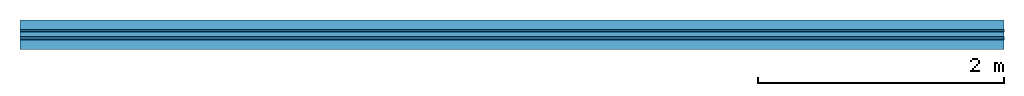
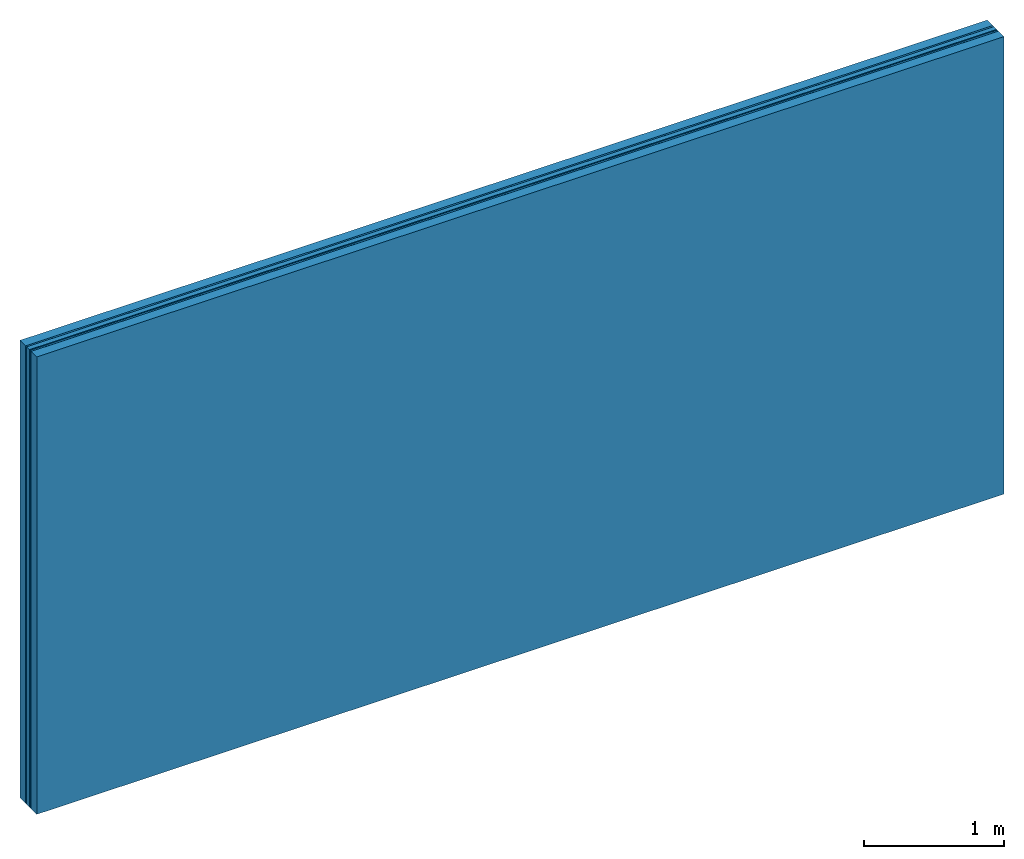
# One storey: 4 plates, 2 members, 1 element without a shape of its own.
"""IFC4 building model written with IfcOpenShell, lengths in metres."""

import ifcopenshell
import ifcopenshell.guid

model = None  # the IFC model being written
_history = None  # IfcOwnerHistory: only IFC2X3 demands one
_inside = {}  # id of a spatial element -> (the spatial element, [elements in it])
_under = {}  # id of a project, library or spatial element -> (it, [spatial elements below it])
_declared = {}  # id of a project -> (the project, [libraries it declares])
_typed = {}  # id of a type object -> (the type object, [elements of that type])
_made_of = {}  # id of a material, layer set ... -> (it, [elements and type objects made of it])


def new_model(schema):
    """Start an empty IFC model of exactly this schema.

    Asked for "IFC4X3", IfcOpenShell would pick the latest addendum, in which some entities
    have other attributes; the version numbers below select the first issue.
    IFC2X3 requires an IfcOwnerHistory on every rooted entity: one is made here for all.
    """
    global model, _history
    if schema == "IFC4X3":
        model = ifcopenshell.file(schema_version=(4, 3, 0, 0))
    else:
        model = ifcopenshell.file(schema=schema)
    _inside.clear()
    _under.clear()
    _declared.clear()
    _typed.clear()
    _made_of.clear()
    _history = None
    if model.schema == "IFC2X3":
        org = make("IfcOrganization", Name="unknown")
        user = make(
            "IfcPersonAndOrganization",
            ThePerson=make("IfcPerson", FamilyName="unknown"),
            TheOrganization=org,
        )
        app = make(
            "IfcApplication",
            ApplicationDeveloper=org,
            Version="unknown",
            ApplicationFullName="unknown",
            ApplicationIdentifier="unknown",
        )
        _history = make(
            "IfcOwnerHistory",
            OwningUser=user,
            OwningApplication=app,
            ChangeAction="ADDED",
            CreationDate=0,
        )
    return model


def make(cls, **values):
    """One entity of the class cls with the attributes given. An attribute that is None is left unset."""
    return model.create_entity(
        cls, **{name: value for name, value in values.items() if value is not None}
    )


def rooted(cls, **values):
    """An entity with a GlobalId (a new one), such as an element, a storey or a relation."""
    return make(cls, GlobalId=ifcopenshell.guid.new(), OwnerHistory=_history, **values)


def si_unit(unit_type, name, prefix=None):
    """IfcSIUnit, for example si_unit("LENGTHUNIT", "METRE", prefix="MILLI")."""
    return make("IfcSIUnit", UnitType=unit_type, Prefix=prefix, Name=name)


def derived_unit(unit_type, elements):
    """IfcDerivedUnit: a product of units, each with its exponent."""
    return make(
        "IfcDerivedUnit",
        Elements=[
            make("IfcDerivedUnitElement", Unit=unit, Exponent=power)
            for unit, power in elements
        ],
        UnitType=unit_type,
    )


def assignment(units):
    """IfcUnitAssignment: the units of a project."""
    return None if units is None else make("IfcUnitAssignment", Units=units)


def point(xyz):
    """IfcCartesianPoint."""
    return None if xyz is None else make("IfcCartesianPoint", Coordinates=xyz)


def direction(xyz):
    """IfcDirection."""
    return None if xyz is None else make("IfcDirection", DirectionRatios=xyz)


def frame(location, z_axis=None, x_axis=None):
    """IfcAxis2Placement3D, a coordinate frame: its origin and axes. An axis left out is left unset."""
    return make(
        "IfcAxis2Placement3D",
        Location=point(location),
        Axis=direction(z_axis),
        RefDirection=direction(x_axis),
    )


def frame_2d(location, x_axis=None):
    """IfcAxis2Placement2D, a coordinate frame in the plane: its origin and x axis."""
    return make(
        "IfcAxis2Placement2D", Location=point(location), RefDirection=direction(x_axis)
    )


def origin():
    """The frame at (0, 0, 0) with its axes left unset."""
    return frame((0.0, 0.0, 0.0))


def place(relative_to, where):
    """IfcLocalPlacement: puts the frame where relative to a parent placement (None: the world)."""
    return make(
        "IfcLocalPlacement", PlacementRelTo=relative_to, RelativePlacement=where
    )


def context(
    kind, dimensions, precision=None, world=None, true_north=None, identifier=None
):
    """IfcGeometricRepresentationContext, for example the 3D "Model" context."""
    return make(
        "IfcGeometricRepresentationContext",
        ContextIdentifier=identifier,
        ContextType=kind,
        CoordinateSpaceDimension=dimensions,
        Precision=precision,
        WorldCoordinateSystem=world,
        TrueNorth=true_north,
    )


def project(units=None, contexts=None):
    """IfcProject with its units and contexts."""
    return rooted(
        "IfcProject",
        Name="project",
        RepresentationContexts=contexts,
        UnitsInContext=assignment(units),
    )


def spatial(cls, under=None, at=None, **own):
    """A site, building, storey or space (cls), placed at a placement, below another one or the project."""
    s = rooted(cls, ObjectPlacement=at, **own)
    if under is not None:
        _under.setdefault(under.id(), (under, []))[1].append(s)
    return s


def profile(cls, at=None, kind="AREA", **sizes):
    """A parametric profile (cls). Its sizes go by their IFC names, for example OverallWidth=200.0."""
    return make(cls, ProfileType=kind, Position=at, **sizes)


def rectangle(**sizes):
    """IfcRectangleProfileDef."""
    return profile("IfcRectangleProfileDef", **sizes)


def extrude(swept, where, along, depth):
    """IfcExtrudedAreaSolid: the profile swept, set in the frame where, extruded along a direction by depth."""
    return make(
        "IfcExtrudedAreaSolid",
        SweptArea=swept,
        Position=where,
        ExtrudedDirection=direction(along),
        Depth=depth,
    )


def shape(context_of_items, identifier, shape_type, items):
    """IfcShapeRepresentation: the items that make up one representation, for example the "Body"."""
    return make(
        "IfcShapeRepresentation",
        ContextOfItems=context_of_items,
        RepresentationIdentifier=identifier,
        RepresentationType=shape_type,
        Items=items,
    )


def material(Name=None, Category=None):
    """IfcMaterial."""
    return make("IfcMaterial", Name=Name, Category=Category)


def layer(
    of_material, thickness, ventilated=None, Name=None, Category=None, Priority=None
):
    """IfcMaterialLayer: one layer of a wall or slab, of a material (None: an air gap)."""
    return make(
        "IfcMaterialLayer",
        Material=of_material,
        LayerThickness=thickness,
        IsVentilated=ventilated,
        Name=Name,
        Category=Category,
        Priority=Priority,
    )


def layer_set(layers, Name=None):
    """IfcMaterialLayerSet."""
    return make("IfcMaterialLayerSet", MaterialLayers=layers, LayerSetName=Name)


def made_of(thing, what):
    """Note that an element or type object is made of a material, layer set ...; save() writes the relation."""
    if what is not None:
        _made_of.setdefault(what.id(), (what, []))[1].append(thing)
    return thing


def type_object(cls, material=None, **own):
    """A type object (cls), such as IfcWallType, which elements share."""
    return made_of(rooted(cls, **own), material)


def element(
    cls,
    number,
    at=None,
    inside=None,
    cuts=None,
    type_object=None,
    material=None,
    context=None,
    identifier="Body",
    shape_type=None,
    held_by="IfcProductDefinitionShape",
    body=None,
    shapes=None,
    **own,
):
    """One element of the class cls, such as IfcWall. Its Tag is "e" and its number.

    at: its placement. inside: the storey or other place that contains it. cuts: it is an
    opening in that element (IfcRelVoidsElement). A single representation is given by context,
    identifier, shape_type and body (its items); several are given by shapes. held_by: the class
    of the entity that holds the representations. save() writes the other relations.
    """
    e = rooted(cls, Tag="e%d" % number, ObjectPlacement=at, **own)
    if body is not None:
        shapes = [shape(context, identifier, shape_type, body)]
    if shapes is not None:
        e.Representation = make(held_by, Representations=shapes)
    if inside is not None:
        _inside.setdefault(inside.id(), (inside, []))[1].append(e)
    if cuts is not None:
        rooted(
            "IfcRelVoidsElement", RelatingBuildingElement=cuts, RelatedOpeningElement=e
        )
    if type_object is not None:
        _typed.setdefault(type_object.id(), (type_object, []))[1].append(e)
    return made_of(e, material)


def aggregate(whole, parts):
    """IfcRelAggregates: a whole, such as a stair, and the parts it consists of."""
    return rooted("IfcRelAggregates", RelatingObject=whole, RelatedObjects=parts)


def save(model, path):
    """Write the relations noted so far, then the file.

    IfcRelAggregates (storeys below a building ...), IfcRelContainedInSpatialStructure (elements
    in a storey), IfcRelDefinesByType, IfcRelAssociatesMaterial and IfcRelDeclares: one each for
    every whole, place, type object, material and project.
    """
    for whole, parts in _under.values():
        aggregate(whole, parts)
    for where, things in _inside.values():
        rooted(
            "IfcRelContainedInSpatialStructure",
            RelatedElements=things,
            RelatingStructure=where,
        )
    for kind, things in _typed.values():
        rooted("IfcRelDefinesByType", RelatedObjects=things, RelatingType=kind)
    for what, things in _made_of.values():
        rooted("IfcRelAssociatesMaterial", RelatedObjects=things, RelatingMaterial=what)
    for by, libraries in _declared.values():
        rooted("IfcRelDeclares", RelatingContext=by, RelatedDefinitions=libraries)
    model.write(path)


model = new_model("IFC4")

# Units and contexts
plan_context = context("Plan", 3, precision=1e-05, world=origin(), true_north=direction((0.0, 1.0)))
model_context = context("Model", 3, precision=1e-05, world=origin(), true_north=direction((0.0, 1.0)))
ifc_project = project(units=[si_unit("LENGTHUNIT", "METRE"), derived_unit("SOUNDPRESSUREUNIT", [(si_unit("PRESSUREUNIT", "PASCAL", prefix="MICRO"), 0)]), si_unit("ENERGYUNIT", "JOULE", prefix="MEGA"), si_unit("MASSUNIT", "GRAM", prefix="KILO"), derived_unit("THERMALTRANSMITTANCEUNIT", [(si_unit("POWERUNIT", "WATT"), 1), (si_unit("AREAUNIT", "SQUARE_METRE"), -1), (si_unit("THERMODYNAMICTEMPERATUREUNIT", "KELVIN"), -1)]), derived_unit("AREADENSITYUNIT", [(si_unit("MASSUNIT", "GRAM", prefix="KILO"), 1), (si_unit("AREAUNIT", "SQUARE_METRE"), -1)]), derived_unit("USERDEFINED", [(si_unit("ENERGYUNIT", "JOULE", prefix="MEGA"), 1), (si_unit("AREAUNIT", "SQUARE_METRE"), -1)])], contexts=[plan_context, model_context])

# Site, building, storey
site = spatial("IfcSite", under=ifc_project)
building_placement = place(None, origin())
building = spatial("IfcBuilding", under=site, at=building_placement)
storey_placement = place(building_placement, origin())
storey = spatial("IfcBuildingStorey", under=building, at=storey_placement)

# Wall, members, plates
ifc_material_1 = material(Name="of the art")
ifc_layer_1 = layer(ifc_material_1, 0.0, Name="Bond")
ifc_layer_2 = layer(None, 0.08, Name="Support")
ifc_layer_3 = layer(ifc_material_1, 0.0, Name="Bond")
ifc_material_2 = material(Category="03.007")
ifc_layer_4 = layer(ifc_material_2, 0.015, Name="outside 1st layer")
ifc_material_3 = material(Category="10.008")
ifc_layer_5 = layer(ifc_material_3, 0.04, Name="Intermediate insulation")
ifc_material_4 = material(Name="Air")
ifc_layer_6 = layer(ifc_material_4, 0.01, Name="Air gap")
ifc_layer_7 = layer(ifc_material_2, 0.015, Name="outside 1st layer")
ifc_layer_8 = layer(ifc_material_1, 0.0, Name="Bond")
ifc_layer_9 = layer(None, 0.08, Name="Support")
ifc_layer_10 = layer(ifc_material_1, 0.0, Name="Bond")
ifc_layer_set = layer_set([ifc_layer_1, ifc_layer_2, ifc_layer_3, ifc_layer_4, ifc_layer_5, ifc_layer_6, ifc_layer_7, ifc_layer_8, ifc_layer_9, ifc_layer_10])
wall_type = type_object("IfcWallType", Name="B0254", PredefinedType="NOTDEFINED", material=ifc_layer_set)
wall_placement = place(None, frame((0.0, 0.0, 0.0), z_axis=(0.0, -1.0, 0.0), x_axis=(1.0, 0.0, 0.0)))
wall = element("IfcWall", 1, at=wall_placement, inside=storey, type_object=wall_type, material=ifc_layer_set, Name="Wall #1")
ifc_material_5 = material(Name="Solid timber panel")
member_1_placement = place(wall_placement, origin())
member_1 = element("IfcMember", 2, at=member_1_placement, material=ifc_material_5, Name="Support", context=plan_context, shape_type="SweptSolid", body=[
    extrude(rectangle(XDim=1.0, YDim=0.08, at=frame_2d((0.5, 0.04), x_axis=(1.0, 0.0))), frame((0.0, 4.0, 0.0), z_axis=(0.0, -1.0, 0.0), x_axis=(1.0, 0.0, 0.0)), (0.0, 0.0, 1.0), 4.0),
    extrude(rectangle(XDim=1.0, YDim=0.08, at=frame_2d((0.5, 0.04), x_axis=(1.0, 0.0))), frame((1.0, 4.0, 0.0), z_axis=(0.0, -1.0, 0.0), x_axis=(1.0, 0.0, 0.0)), (0.0, 0.0, 1.0), 4.0),
    extrude(rectangle(XDim=1.0, YDim=0.08, at=frame_2d((0.5, 0.04), x_axis=(1.0, 0.0))), frame((2.0, 4.0, 0.0), z_axis=(0.0, -1.0, 0.0), x_axis=(1.0, 0.0, 0.0)), (0.0, 0.0, 1.0), 4.0),
    extrude(rectangle(XDim=1.0, YDim=0.08, at=frame_2d((0.5, 0.04), x_axis=(1.0, 0.0))), frame((3.0, 4.0, 0.0), z_axis=(0.0, -1.0, 0.0), x_axis=(1.0, 0.0, 0.0)), (0.0, 0.0, 1.0), 4.0),
    extrude(rectangle(XDim=1.0, YDim=0.08, at=frame_2d((0.5, 0.04), x_axis=(1.0, 0.0))), frame((4.0, 4.0, 0.0), z_axis=(0.0, -1.0, 0.0), x_axis=(1.0, 0.0, 0.0)), (0.0, 0.0, 1.0), 4.0),
    extrude(rectangle(XDim=1.0, YDim=0.08, at=frame_2d((0.5, 0.04), x_axis=(1.0, 0.0))), frame((5.0, 4.0, 0.0), z_axis=(0.0, -1.0, 0.0), x_axis=(1.0, 0.0, 0.0)), (0.0, 0.0, 1.0), 4.0),
    extrude(rectangle(XDim=1.0, YDim=0.08, at=frame_2d((0.5, 0.04), x_axis=(1.0, 0.0))), frame((6.0, 4.0, 0.0), z_axis=(0.0, -1.0, 0.0), x_axis=(1.0, 0.0, 0.0)), (0.0, 0.0, 1.0), 4.0),
    extrude(rectangle(XDim=1.0, YDim=0.08, at=frame_2d((0.5, 0.04), x_axis=(1.0, 0.0))), frame((7.0, 4.0, 0.0), z_axis=(0.0, -1.0, 0.0), x_axis=(1.0, 0.0, 0.0)), (0.0, 0.0, 1.0), 4.0),
])
member_2_placement = place(wall_placement, origin())
member_2 = element("IfcMember", 3, at=member_2_placement, material=ifc_material_5, Name="Support", context=plan_context, shape_type="SweptSolid", body=[
    extrude(rectangle(XDim=1.0, YDim=0.08, at=frame_2d((0.5, 0.04), x_axis=(1.0, 0.0))), frame((0.0, 4.0, 0.16), z_axis=(0.0, -1.0, 0.0), x_axis=(1.0, 0.0, 0.0)), (0.0, 0.0, 1.0), 4.0),
    extrude(rectangle(XDim=1.0, YDim=0.08, at=frame_2d((0.5, 0.04), x_axis=(1.0, 0.0))), frame((1.0, 4.0, 0.16), z_axis=(0.0, -1.0, 0.0), x_axis=(1.0, 0.0, 0.0)), (0.0, 0.0, 1.0), 4.0),
    extrude(rectangle(XDim=1.0, YDim=0.08, at=frame_2d((0.5, 0.04), x_axis=(1.0, 0.0))), frame((2.0, 4.0, 0.16), z_axis=(0.0, -1.0, 0.0), x_axis=(1.0, 0.0, 0.0)), (0.0, 0.0, 1.0), 4.0),
    extrude(rectangle(XDim=1.0, YDim=0.08, at=frame_2d((0.5, 0.04), x_axis=(1.0, 0.0))), frame((3.0, 4.0, 0.16), z_axis=(0.0, -1.0, 0.0), x_axis=(1.0, 0.0, 0.0)), (0.0, 0.0, 1.0), 4.0),
    extrude(rectangle(XDim=1.0, YDim=0.08, at=frame_2d((0.5, 0.04), x_axis=(1.0, 0.0))), frame((4.0, 4.0, 0.16), z_axis=(0.0, -1.0, 0.0), x_axis=(1.0, 0.0, 0.0)), (0.0, 0.0, 1.0), 4.0),
    extrude(rectangle(XDim=1.0, YDim=0.08, at=frame_2d((0.5, 0.04), x_axis=(1.0, 0.0))), frame((5.0, 4.0, 0.16), z_axis=(0.0, -1.0, 0.0), x_axis=(1.0, 0.0, 0.0)), (0.0, 0.0, 1.0), 4.0),
    extrude(rectangle(XDim=1.0, YDim=0.08, at=frame_2d((0.5, 0.04), x_axis=(1.0, 0.0))), frame((6.0, 4.0, 0.16), z_axis=(0.0, -1.0, 0.0), x_axis=(1.0, 0.0, 0.0)), (0.0, 0.0, 1.0), 4.0),
    extrude(rectangle(XDim=1.0, YDim=0.08, at=frame_2d((0.5, 0.04), x_axis=(1.0, 0.0))), frame((7.0, 4.0, 0.16), z_axis=(0.0, -1.0, 0.0), x_axis=(1.0, 0.0, 0.0)), (0.0, 0.0, 1.0), 4.0),
])
plate_1_placement = place(wall_placement, origin())
plate_1 = element("IfcPlate", 4, at=plate_1_placement, material=ifc_material_2, Name="outside 1st layer", context=plan_context, shape_type="SweptSolid", body=[
    extrude(rectangle(XDim=8.0, YDim=4.0, at=frame_2d((4.0, 2.0), x_axis=(1.0, 0.0))), frame((0.0, 0.0, 0.08), z_axis=(0.0, 0.0, 1.0), x_axis=(1.0, 0.0, 0.0)), (0.0, 0.0, 1.0), 0.015),
])
plate_2_placement = place(wall_placement, origin())
plate_2 = element("IfcPlate", 5, at=plate_2_placement, material=ifc_material_3, Name="Intermediate insulation", context=plan_context, shape_type="SweptSolid", body=[
    extrude(rectangle(XDim=8.0, YDim=4.0, at=frame_2d((4.0, 2.0), x_axis=(1.0, 0.0))), frame((0.0, 0.0, 0.095), z_axis=(0.0, 0.0, 1.0), x_axis=(1.0, 0.0, 0.0)), (0.0, 0.0, 1.0), 0.04),
])
plate_3_placement = place(wall_placement, origin())
plate_3 = element("IfcPlate", 6, at=plate_3_placement, material=ifc_material_4, Name="Air gap", context=plan_context, shape_type="SweptSolid", body=[
    extrude(rectangle(XDim=8.0, YDim=4.0, at=frame_2d((4.0, 2.0), x_axis=(1.0, 0.0))), frame((0.0, 0.0, 0.135), z_axis=(0.0, 0.0, 1.0), x_axis=(1.0, 0.0, 0.0)), (0.0, 0.0, 1.0), 0.01),
])
plate_4_placement = place(wall_placement, origin())
plate_4 = element("IfcPlate", 7, at=plate_4_placement, material=ifc_material_2, Name="outside 1st layer", context=plan_context, shape_type="SweptSolid", body=[
    extrude(rectangle(XDim=8.0, YDim=4.0, at=frame_2d((4.0, 2.0), x_axis=(1.0, 0.0))), frame((0.0, 0.0, 0.145), z_axis=(0.0, 0.0, 1.0), x_axis=(1.0, 0.0, 0.0)), (0.0, 0.0, 1.0), 0.015),
])
aggregate(wall, [member_1, plate_1, plate_2, plate_3, plate_4, member_2])

save(model, "model.ifc")
